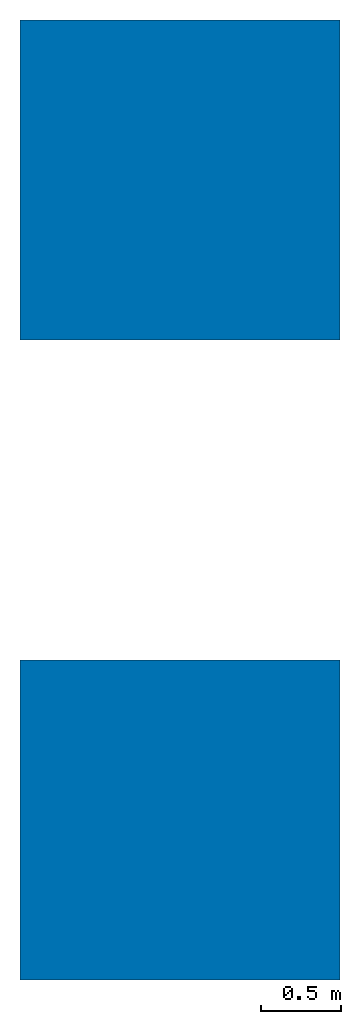
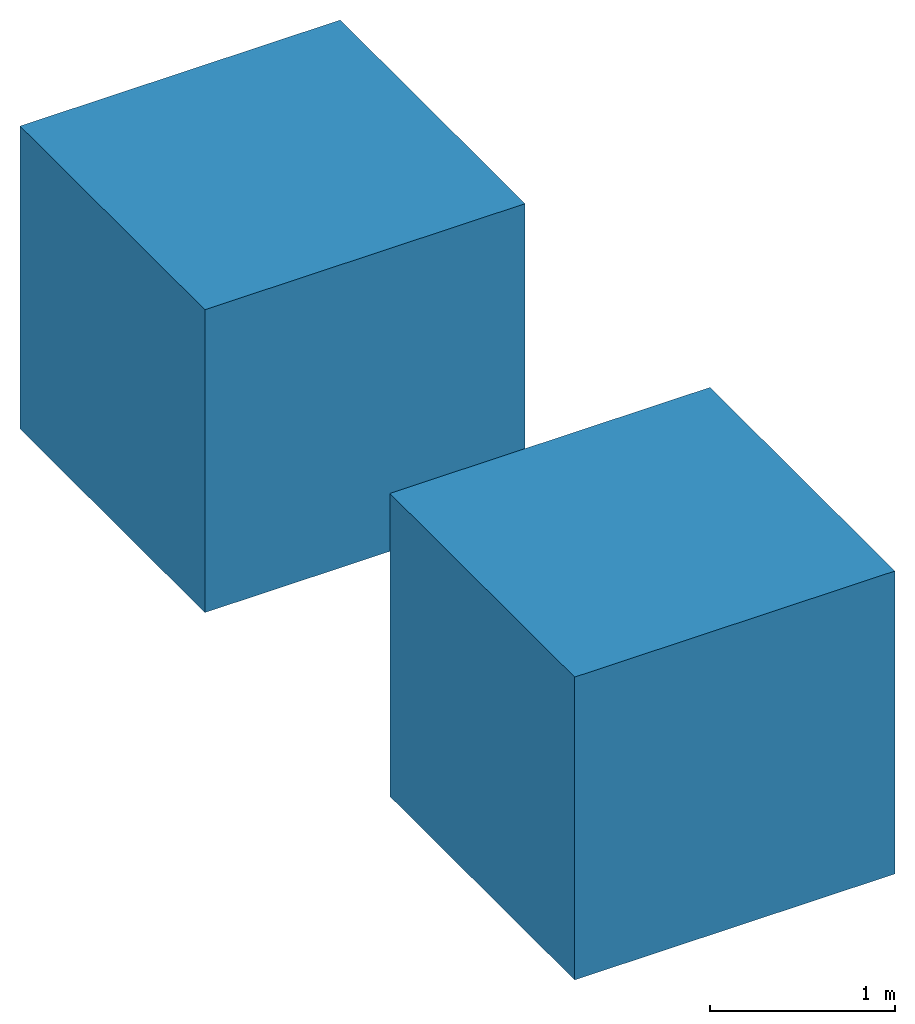
# One storey: 2 walls.
"""IFC4 building model written with IfcOpenShell, lengths in millimetres."""

from ifc_helpers import new_model, si_unit, direction, frame, frame_2d, origin_with_axes, origin_2d_with_axis, place, context, subcontext, project, spatial, rectangle, extrude, source, transform, mapped, material, type_object, type_shapes, element, save


model = new_model("IFC4")

# Units and contexts
model_context = context("Model", 3, precision=1e-05, world=origin_with_axes(), true_north=direction((1.0, 0.0)))
body_context = subcontext(model_context, "Body", "Model", "MODEL_VIEW")
ifc_project = project(units=[si_unit("LENGTHUNIT", "METRE", prefix="MILLI"), si_unit("AREAUNIT", "SQUARE_METRE"), si_unit("VOLUMEUNIT", "CUBIC_METRE"), si_unit("PLANEANGLEUNIT", "RADIAN"), si_unit("TIMEUNIT", "SECOND"), si_unit("MASSUNIT", "GRAM")], contexts=[model_context])

# Site, building, storey
site_placement = place(None, origin_with_axes())
site = spatial("IfcSite", under=ifc_project, at=site_placement, CompositionType="ELEMENT")
building_placement = place(site_placement, origin_with_axes())
building = spatial("IfcBuilding", under=site, at=building_placement, Name="Building", CompositionType="ELEMENT")
storey_placement = place(building_placement, origin_with_axes())
storey = spatial("IfcBuildingStorey", under=building, at=storey_placement, Name="Ground Floor", CompositionType="ELEMENT", Elevation=0.0)

# Walls
wall_type_1 = type_object("IfcWallType", Name="Green Cube7074", PredefinedType="NOTDEFINED")
shared_shape_1 = source(origin_with_axes(), body_context, "Body", "SweptSolid", [
    extrude(rectangle(XDim=2000.0, YDim=2000.0, at=origin_2d_with_axis()), frame((0.0, 0.0, -1000.0), z_axis=(0.0, 0.0, 1.0), x_axis=(1.0, 0.0, 0.0)), (0.0, 0.0, 1.0), 2000.0),
])
type_shapes(wall_type_1, [shared_shape_1])
wall_1_placement = place(storey_placement, frame((0.0, 4000.0, 0.0), z_axis=(0.0, 0.0, 1.0), x_axis=(1.0, 0.0, 0.0)))
element("IfcWall", 1, at=wall_1_placement, inside=storey, type_object=wall_type_1, Name="Green Cube", context=body_context, shape_type="MappedRepresentation", body=[
    mapped(shared_shape_1, transform((0.0, 0.0, 0.0), x_axis=(1.0, 0.0, 0.0), y_axis=(0.0, 1.0, 0.0), z_axis=(0.0, 0.0, 1.0), scale=1.0)),
])
ifc_material = material(Name="red")
wall_type_2 = type_object("IfcWallType", Name="Red Cube7074", PredefinedType="NOTDEFINED")
shared_shape_2 = source(origin_with_axes(), body_context, "Body", "SweptSolid", [
    extrude(rectangle(XDim=2000.000134358852, YDim=2000.000134358852, at=frame_2d((0.0, 0.0), x_axis=(0.0, 1.0))), frame((0.0, 0.0, -1000.0), z_axis=(0.0, 0.0, 1.0), x_axis=(1.0, 0.0, 0.0)), (0.0, 0.0, 1.0), 2000.0),
])
type_shapes(wall_type_2, [shared_shape_2])
wall_2_placement = place(storey_placement, origin_with_axes())
element("IfcWall", 2, at=wall_2_placement, inside=storey, type_object=wall_type_2, material=ifc_material, Name="Red Cube", context=body_context, shape_type="MappedRepresentation", body=[
    mapped(shared_shape_2, transform((0.0, 0.0, 0.0), x_axis=(1.0, 0.0, 0.0), y_axis=(0.0, 1.0, 0.0), z_axis=(0.0, 0.0, 1.0), scale=1.0)),
])

save(model, "model.ifc")
